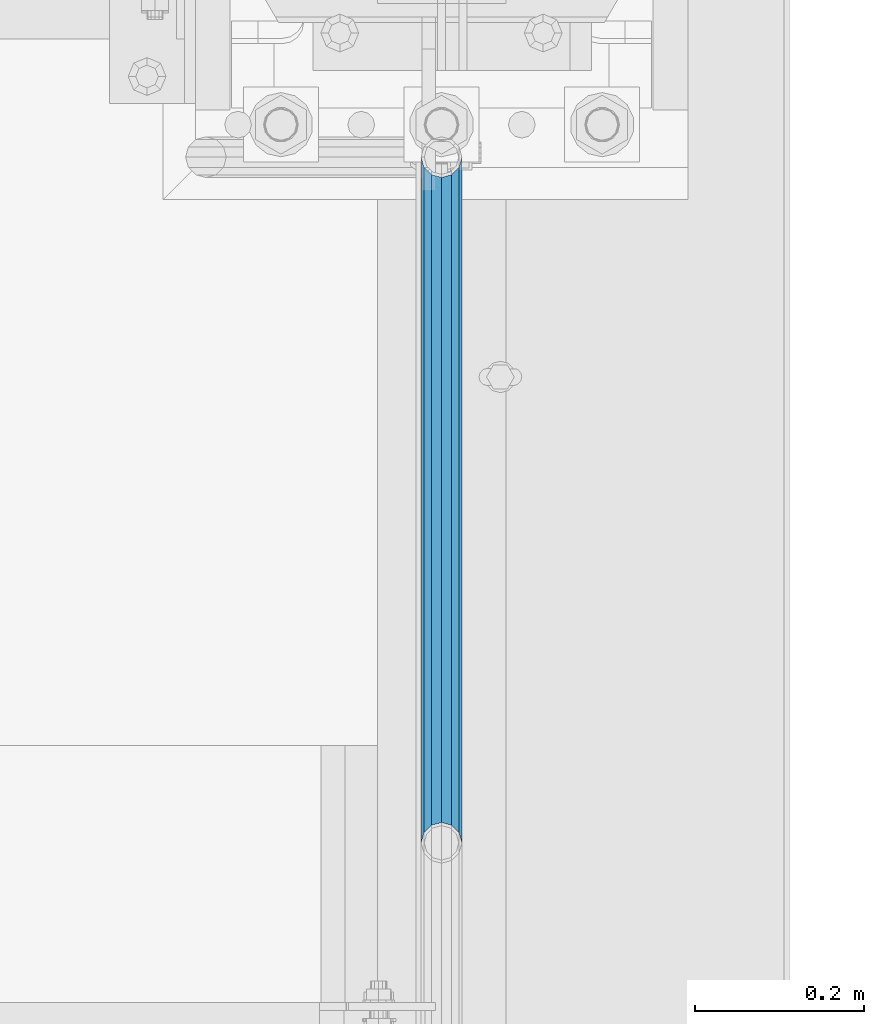
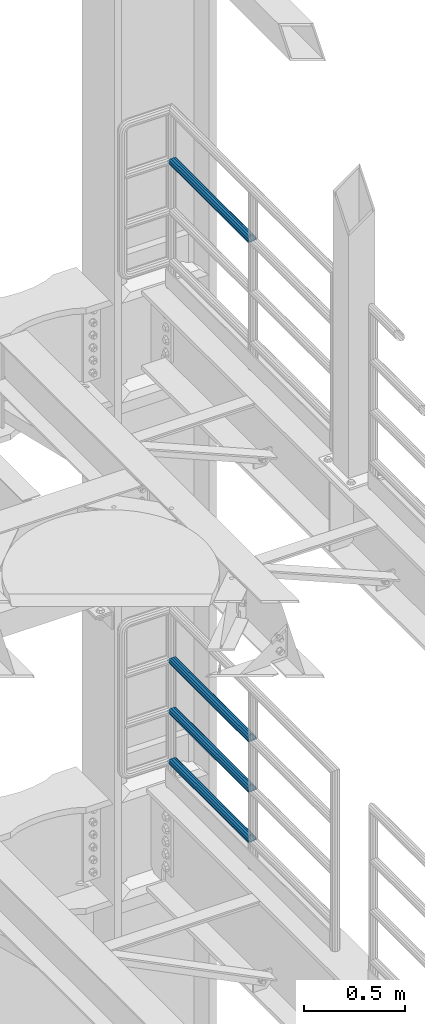
# One storey, part 1352 of 1876: 4 beams, 2 elements without a shape of their own.
"""IFC2X3 building model written with IfcOpenShell, lengths in millimetres."""

from ifc_helpers import new_model, si_unit, frame, origin_with_axes, place, context, subcontext, project, spatial, faceted_brep, material, type_object, element, aggregate, save


model = new_model("IFC2X3")

# Units and contexts
model_context = context("Model", 3, precision=1e-05, world=origin_with_axes())
body_context = subcontext(model_context, "Body", "Model", "MODEL_VIEW")
ifc_project = project(units=[si_unit("LENGTHUNIT", "METRE", prefix="MILLI"), si_unit("AREAUNIT", "SQUARE_METRE"), si_unit("VOLUMEUNIT", "CUBIC_METRE"), si_unit("MASSUNIT", "GRAM", prefix="KILO"), si_unit("TIMEUNIT", "SECOND"), si_unit("PLANEANGLEUNIT", "RADIAN"), si_unit("SOLIDANGLEUNIT", "STERADIAN"), si_unit("THERMODYNAMICTEMPERATUREUNIT", "DEGREE_CELSIUS"), si_unit("LUMINOUSINTENSITYUNIT", "LUMEN")], contexts=[model_context])

# Site, building, storey
site_placement = place(None, origin_with_axes())
site = spatial("IfcSite", under=ifc_project, at=site_placement, CompositionType="ELEMENT")
building_placement = place(site_placement, origin_with_axes())
building = spatial("IfcBuilding", under=site, at=building_placement, Name="Undefined", CompositionType="ELEMENT")
storey_placement = place(building_placement, origin_with_axes())
storey = spatial("IfcBuildingStorey", under=building, at=storey_placement, Name="Undefined", CompositionType="ELEMENT", Elevation=0.0)

# Assembly, beam
assembly_1_placement = place(storey_placement, origin_with_axes())
assembly_1 = element("IfcElementAssembly", 1, at=assembly_1_placement, inside=storey, Name="RAIL", AssemblyPlace="NOTDEFINED", PredefinedType="RIGID_FRAME")
ifc_material = material()
beam_type = type_object("IfcBeamType", Name="PIPE1-1/2SCH40", PredefinedType="NOTDEFINED")
beam_1_placement = place(assembly_1_placement, frame((7620.0, 12686.3094, 8924.925), z_axis=(0.0, 0.0, -1.0), x_axis=(0.0, 1.0, 0.0)))
beam_1 = element("IfcBeam", 2, at=beam_1_placement, type_object=beam_type, material=ifc_material, Name="RAIL", ObjectType="PIPE1-1/2SCH40", context=body_context, shape_type="Brep", body=[
    faceted_brep([(0.0, 24.1299999999992, 0.0), (12.0650000000064, 20.8971929933177, -12.0649999999987), (12.0650000000064, 20.8971929933177, 12.0649999999987), (12.0650000000064, -20.8971929933177, 12.0649999999987), (12.0650000000064, -20.8971929933177, -12.0649999999987), (0.0, -24.1299999999992, 0.0), (20.8971929933249, -12.0650000000005, 20.8971929933177), (20.8971929933249, -12.0650000000005, 15.8661214311796), (15.2545715621445, -17.7076214311801, 10.2235000000001), (12.5151929933249, -20.4470000000001, 0.0), (15.2545715621445, -17.7076214311801, -10.2235000000001), (20.8971929933249, -12.0650000000005, -15.8661214311796), (20.8971929933249, -12.0650000000005, -20.8971929933177), (24.1300000000063, 0.0, -20.4470000000001), (24.1300000000063, 0.0, -24.130000000001), (21.3906214311868, -10.2235000000001, -17.7076214311819), (21.3906214311868, 10.2235000000001, -17.7076214311819), (20.8971929933249, 12.0650000000005, -15.8661214311796), (20.8971929933249, 12.0650000000005, -20.8971929933177), (15.2545715621445, 17.7076214311801, -10.2235000000001), (12.5151929933249, 20.4470000000001, 0.0), (15.2545715621445, 17.7076214311801, 10.2235000000001), (20.8971929933249, 12.0650000000005, 15.8661214311796), (20.8971929933249, 12.0650000000005, 20.8971929933177), (21.3906214311868, 10.2235000000001, 17.7076214311819), (24.1300000000064, 0.0, 20.4470000000001), (24.1300000000064, 0.0, 24.130000000001), (21.3906214311868, -10.2235000000001, 17.7076214311819), (813.396900000002, 24.1300000000001, 0.0), (801.331900000001, 20.8971929933186, -12.0649999999987), (792.499707006684, 12.0649999999996, -20.8971929933177), (813.396900000002, -24.1300000000319, 0.0), (801.331900000001, -20.8971929933186, -12.0649999999987), (801.331900000001, -20.8971929933186, 12.0649999999987), (792.499707006684, -12.0649999999996, 20.8971929933177), (792.499707006684, -12.0649999999996, -20.8971929933177), (789.266900000001, 0.0, -24.130000000001), (792.00627856883, 10.2235000000001, -17.7076214311819), (789.266900000001, 0.0, -20.4470000000001), (792.499707006684, 12.0649999999678, -15.8661214312124), (792.499707006684, -12.0650000000314, -15.8661214311469), (792.006278568813, -10.2235000000001, -17.7076214311819), (798.142328437831, -17.7076214311801, -10.2235000000001), (800.881707006651, -20.4470000000001, 0.0), (798.142328437831, -17.7076214311801, 10.2235000000001), (792.499707006684, -12.0650000000314, 15.8661214311469), (792.006278568813, -10.2235000000001, 17.7076214311819), (789.266900000001, -9.09494701772928e-13, 20.4470000000001), (789.266900000001, -9.09494701772928e-13, 24.130000000001), (792.499707006684, 12.0649999999996, 20.8971929933177), (801.331900000001, 20.8971929933186, 12.0649999999987), (792.499707006684, 12.0649999999678, 15.8661214312124), (798.142328437896, 17.7076214311801, 10.2235000000001), (800.881707006714, 20.4470000000001, 0.0), (798.142328437896, 17.7076214311801, -10.2235000000001), (792.00627856883, 10.2235000000001, 17.7076214311819)], [[[0, 1, 2]], [[3, 4, 5]], [[6, 7, 8, 9, 10, 11, 12, 4, 3]], [[13, 14, 12, 11, 15]], [[16, 17, 18, 14, 13]], [[2, 1, 18, 17, 19, 20, 21, 22, 23]], [[23, 22, 24, 25, 26]], [[26, 25, 27, 7, 6]], [[1, 0, 28, 29]], [[18, 1, 29, 30]], [[31, 32, 33]], [[6, 3, 33, 34]], [[3, 5, 31, 33]], [[5, 4, 32, 31]], [[4, 12, 35, 32]], [[12, 14, 36, 35]], [[14, 18, 30, 36]], [[37, 38, 36, 30, 39]], [[40, 35, 36, 38, 41]], [[33, 32, 35, 40, 42, 43, 44, 45, 34]], [[34, 45, 46, 47, 48]], [[26, 6, 34, 48]], [[2, 23, 49, 50]], [[23, 26, 48, 49]], [[0, 2, 50, 28]], [[28, 50, 29]], [[49, 51, 52, 53, 54, 39, 30, 29, 50]], [[48, 47, 55, 51, 49]], [[25, 24, 55, 47]], [[55, 24, 22, 21, 52, 51]], [[21, 20, 53, 52]], [[20, 19, 54, 53]], [[19, 17, 16, 37, 39, 54]], [[16, 13, 38, 37]], [[13, 15, 41, 38]], [[41, 15, 11, 10, 42, 40]], [[10, 9, 43, 42]], [[9, 8, 44, 43]], [[8, 7, 27, 46, 45, 44]], [[27, 25, 47, 46]]]),
])
aggregate(assembly_1, [beam_1])

# Assembly, beams
assembly_2_placement = place(storey_placement, origin_with_axes())
assembly_2 = element("IfcElementAssembly", 3, at=assembly_2_placement, inside=storey, Name="RAIL", AssemblyPlace="NOTDEFINED", PredefinedType="RIGID_FRAME")
beam_2_placement = place(assembly_2_placement, frame((7620.00000000002, 13499.7063, 5292.725), z_axis=(0.0, 0.0, 1.0), x_axis=(0.0, -1.0, 0.0)))
beam_2 = element("IfcBeam", 4, at=beam_2_placement, type_object=beam_type, material=ifc_material, Name="RAIL", ObjectType="PIPE1-1/2SCH40", context=body_context, shape_type="Brep", body=[
    faceted_brep([(792.499707006684, -12.0649999999996, 20.8971929933177), (792.499707006684, -12.0650000000314, 15.8661214311469), (792.006278568813, -10.2235000000001, 17.7076214311819), (789.266900000001, -9.09494701772928e-13, 20.4470000000001), (789.266900000001, -9.09494701772928e-13, 24.130000000001), (792.00627856883, 10.2235000000001, 17.7076214311819), (792.499707006684, 12.0649999999678, 15.8661214312124), (792.499707006684, 12.0649999999996, 20.8971929933177), (813.396900000002, 24.1300000000001, 0.0), (801.331900000001, 20.8971929933186, 12.0649999999987), (801.331900000001, 20.8971929933186, -12.0649999999987), (798.142328437896, 17.7076214311801, 10.2235000000001), (800.881707006714, 20.4470000000001, 0.0), (798.142328437896, 17.7076214311801, -10.2235000000001), (792.499707006684, 12.0649999999678, -15.8661214312124), (792.499707006684, 12.0649999999996, -20.8971929933177), (792.00627856883, 10.2235000000001, -17.7076214311819), (789.266900000001, 0.0, -20.4470000000001), (789.266900000001, 0.0, -24.130000000001), (792.499707006684, -12.0650000000314, -15.8661214311469), (792.499707006684, -12.0649999999996, -20.8971929933177), (792.006278568813, -10.2235000000001, -17.7076214311819), (813.396900000002, -24.1300000000319, 0.0), (801.331900000001, -20.8971929933186, -12.0649999999987), (801.331900000001, -20.8971929933186, 12.0649999999987), (798.142328437831, -17.7076214311801, -10.2235000000001), (800.881707006651, -20.4470000000001, 0.0), (798.142328437831, -17.7076214311801, 10.2235000000001), (12.0650000000064, -20.8971929933177, -12.0649999999987), (20.8971929933249, -12.0650000000005, -20.8971929933177), (0.0, 24.1299999999992, 0.0), (12.0650000000064, 20.8971929933177, -12.0649999999987), (12.0650000000064, 20.8971929933177, 12.0649999999987), (20.8971929933249, 12.0650000000005, 20.8971929933177), (24.1300000000064, 0.0, 24.130000000001), (20.8971929933249, 12.0650000000005, -20.8971929933177), (24.1300000000063, 0.0, -24.130000000001), (24.1300000000063, 0.0, -20.4470000000001), (20.8971929933249, -12.0650000000005, -15.8661214311796), (21.3906214311868, -10.2235000000001, -17.7076214311819), (21.3906214311868, 10.2235000000001, -17.7076214311819), (20.8971929933249, 12.0650000000005, -15.8661214311796), (15.2545715621445, 17.7076214311801, -10.2235000000001), (12.5151929933249, 20.4470000000001, 0.0), (15.2545715621445, 17.7076214311801, 10.2235000000001), (20.8971929933249, 12.0650000000005, 15.8661214311796), (21.3906214311868, 10.2235000000001, 17.7076214311819), (24.1300000000064, 0.0, 20.4470000000001), (21.3906214311868, -10.2235000000001, 17.7076214311819), (20.8971929933249, -12.0650000000005, 15.8661214311796), (20.8971929933249, -12.0650000000005, 20.8971929933177), (12.0650000000064, -20.8971929933177, 12.0649999999987), (0.0, -24.1299999999992, 0.0), (15.2545715621445, -17.7076214311801, 10.2235000000001), (12.5151929933249, -20.4470000000001, 0.0), (15.2545715621445, -17.7076214311801, -10.2235000000001)], [[[0, 1, 2, 3, 4]], [[4, 3, 5, 6, 7]], [[8, 9, 10]], [[7, 6, 11, 12, 13, 14, 15, 10, 9]], [[16, 17, 18, 15, 14]], [[19, 20, 18, 17, 21]], [[22, 23, 24]], [[24, 23, 20, 19, 25, 26, 27, 1, 0]], [[28, 29, 20, 23]], [[30, 31, 32]], [[33, 34, 4, 7]], [[32, 33, 7, 9]], [[30, 32, 9, 8]], [[31, 30, 8, 10]], [[35, 31, 10, 15]], [[36, 35, 15, 18]], [[29, 36, 18, 20]], [[37, 36, 29, 38, 39]], [[40, 41, 35, 36, 37]], [[32, 31, 35, 41, 42, 43, 44, 45, 33]], [[33, 45, 46, 47, 34]], [[34, 47, 48, 49, 50]], [[34, 50, 0, 4]], [[50, 51, 24, 0]], [[51, 52, 22, 24]], [[52, 28, 23, 22]], [[51, 28, 52]], [[50, 49, 53, 54, 55, 38, 29, 28, 51]], [[55, 54, 26, 25]], [[21, 39, 38, 55, 25, 19]], [[37, 39, 21, 17]], [[40, 37, 17, 16]], [[42, 41, 40, 16, 14, 13]], [[43, 42, 13, 12]], [[44, 43, 12, 11]], [[5, 46, 45, 44, 11, 6]], [[47, 46, 5, 3]], [[48, 47, 3, 2]], [[53, 49, 48, 2, 1, 27]], [[54, 53, 27, 26]]]),
])
beam_3_placement = place(assembly_2_placement, frame((7620.0, 12686.3094, 5597.525), z_axis=(0.0, 0.0, -1.0), x_axis=(0.0, 1.0, 0.0)))
beam_3 = element("IfcBeam", 5, at=beam_3_placement, type_object=beam_type, material=ifc_material, Name="RAIL", ObjectType="PIPE1-1/2SCH40", context=body_context, shape_type="Brep", body=[
    faceted_brep([(0.0, 24.1299999999992, 0.0), (12.0650000000064, 20.8971929933177, -12.0649999999987), (12.0650000000064, 20.8971929933177, 12.0649999999987), (12.0650000000064, -20.8971929933177, 12.0649999999987), (12.0650000000064, -20.8971929933177, -12.0649999999987), (0.0, -24.1299999999992, 0.0), (20.8971929933249, -12.0650000000005, 20.8971929933177), (20.8971929933249, -12.0650000000005, 15.8661214311796), (15.2545715621445, -17.7076214311801, 10.2235000000001), (12.5151929933249, -20.4470000000001, 0.0), (15.2545715621445, -17.7076214311801, -10.2235000000001), (20.8971929933249, -12.0650000000005, -15.8661214311796), (20.8971929933249, -12.0650000000005, -20.8971929933177), (24.1300000000063, 0.0, -20.4470000000001), (24.1300000000063, 0.0, -24.130000000001), (21.3906214311868, -10.2235000000001, -17.7076214311819), (21.3906214311868, 10.2235000000001, -17.7076214311819), (20.8971929933249, 12.0650000000005, -15.8661214311796), (20.8971929933249, 12.0650000000005, -20.8971929933177), (15.2545715621445, 17.7076214311801, -10.2235000000001), (12.5151929933249, 20.4470000000001, 0.0), (15.2545715621445, 17.7076214311801, 10.2235000000001), (20.8971929933249, 12.0650000000005, 15.8661214311796), (20.8971929933249, 12.0650000000005, 20.8971929933177), (21.3906214311868, 10.2235000000001, 17.7076214311819), (24.1300000000064, 0.0, 20.4470000000001), (24.1300000000064, 0.0, 24.130000000001), (21.3906214311868, -10.2235000000001, 17.7076214311819), (813.396900000002, 24.1300000000001, 0.0), (801.331900000001, 20.8971929933186, -12.0649999999987), (792.499707006684, 12.0649999999996, -20.8971929933177), (813.396900000002, -24.1300000000319, 0.0), (801.331900000001, -20.8971929933186, -12.0649999999987), (801.331900000001, -20.8971929933186, 12.0649999999987), (792.499707006684, -12.0649999999996, 20.8971929933177), (792.499707006684, -12.0649999999996, -20.8971929933177), (789.266900000001, 0.0, -24.130000000001), (792.00627856883, 10.2235000000001, -17.7076214311819), (789.266900000001, 0.0, -20.4470000000001), (792.499707006684, 12.0649999999678, -15.8661214312124), (792.499707006684, -12.0650000000314, -15.8661214311469), (792.006278568813, -10.2235000000001, -17.7076214311819), (798.142328437831, -17.7076214311801, -10.2235000000001), (800.881707006651, -20.4470000000001, 0.0), (798.142328437831, -17.7076214311801, 10.2235000000001), (792.499707006684, -12.0650000000314, 15.8661214311469), (792.006278568813, -10.2235000000001, 17.7076214311819), (789.266900000001, -9.09494701772928e-13, 20.4470000000001), (789.266900000001, -9.09494701772928e-13, 24.130000000001), (792.499707006684, 12.0649999999996, 20.8971929933177), (801.331900000001, 20.8971929933186, 12.0649999999987), (792.499707006684, 12.0649999999678, 15.8661214312124), (798.142328437896, 17.7076214311801, 10.2235000000001), (800.881707006714, 20.4470000000001, 0.0), (798.142328437896, 17.7076214311801, -10.2235000000001), (792.00627856883, 10.2235000000001, 17.7076214311819)], [[[0, 1, 2]], [[3, 4, 5]], [[6, 7, 8, 9, 10, 11, 12, 4, 3]], [[13, 14, 12, 11, 15]], [[16, 17, 18, 14, 13]], [[2, 1, 18, 17, 19, 20, 21, 22, 23]], [[23, 22, 24, 25, 26]], [[26, 25, 27, 7, 6]], [[1, 0, 28, 29]], [[18, 1, 29, 30]], [[31, 32, 33]], [[6, 3, 33, 34]], [[3, 5, 31, 33]], [[5, 4, 32, 31]], [[4, 12, 35, 32]], [[12, 14, 36, 35]], [[14, 18, 30, 36]], [[37, 38, 36, 30, 39]], [[40, 35, 36, 38, 41]], [[33, 32, 35, 40, 42, 43, 44, 45, 34]], [[34, 45, 46, 47, 48]], [[26, 6, 34, 48]], [[2, 23, 49, 50]], [[23, 26, 48, 49]], [[0, 2, 50, 28]], [[28, 50, 29]], [[49, 51, 52, 53, 54, 39, 30, 29, 50]], [[48, 47, 55, 51, 49]], [[25, 24, 55, 47]], [[55, 24, 22, 21, 52, 51]], [[21, 20, 53, 52]], [[20, 19, 54, 53]], [[19, 17, 16, 37, 39, 54]], [[16, 13, 38, 37]], [[13, 15, 41, 38]], [[41, 15, 11, 10, 42, 40]], [[10, 9, 43, 42]], [[9, 8, 44, 43]], [[8, 7, 27, 46, 45, 44]], [[27, 25, 47, 46]]]),
])
beam_4_placement = place(assembly_2_placement, frame((7620.0, 12686.3094, 5902.325), z_axis=(0.0, 0.0, -1.0), x_axis=(0.0, 1.0, 0.0)))
beam_4 = element("IfcBeam", 6, at=beam_4_placement, type_object=beam_type, material=ifc_material, Name="RAIL", ObjectType="PIPE1-1/2SCH40", context=body_context, shape_type="Brep", body=[
    faceted_brep([(0.0, 24.1299999999992, 0.0), (12.0650000000064, 20.8971929933177, -12.0649999999987), (12.0650000000064, 20.8971929933177, 12.0649999999987), (12.0650000000064, -20.8971929933177, 12.0649999999987), (12.0650000000064, -20.8971929933177, -12.0649999999987), (0.0, -24.1299999999992, 0.0), (20.8971929933249, -12.0650000000005, 20.8971929933177), (20.8971929933249, -12.0650000000005, 15.8661214311796), (15.2545715621445, -17.7076214311801, 10.2235000000001), (12.5151929933249, -20.4470000000001, 0.0), (15.2545715621445, -17.7076214311801, -10.2235000000001), (20.8971929933249, -12.0650000000005, -15.8661214311796), (20.8971929933249, -12.0650000000005, -20.8971929933177), (24.1300000000063, 0.0, -20.4470000000001), (24.1300000000063, 0.0, -24.130000000001), (21.3906214311868, -10.2235000000001, -17.7076214311819), (21.3906214311868, 10.2235000000001, -17.7076214311819), (20.8971929933249, 12.0650000000005, -15.8661214311796), (20.8971929933249, 12.0650000000005, -20.8971929933177), (15.2545715621445, 17.7076214311801, -10.2235000000001), (12.5151929933249, 20.4470000000001, 0.0), (15.2545715621445, 17.7076214311801, 10.2235000000001), (20.8971929933249, 12.0650000000005, 15.8661214311796), (20.8971929933249, 12.0650000000005, 20.8971929933177), (21.3906214311868, 10.2235000000001, 17.7076214311819), (24.1300000000064, 0.0, 20.4470000000001), (24.1300000000064, 0.0, 24.130000000001), (21.3906214311868, -10.2235000000001, 17.7076214311819), (813.396900000002, 24.1300000000001, 0.0), (801.331900000001, 20.8971929933186, -12.0649999999987), (792.499707006684, 12.0649999999996, -20.8971929933177), (813.396900000002, -24.1300000000319, 0.0), (801.331900000001, -20.8971929933186, -12.0649999999987), (801.331900000001, -20.8971929933186, 12.0649999999987), (792.499707006684, -12.0649999999996, 20.8971929933177), (792.499707006684, -12.0649999999996, -20.8971929933177), (789.266900000001, 0.0, -24.130000000001), (792.00627856883, 10.2235000000001, -17.7076214311819), (789.266900000001, 0.0, -20.4470000000001), (792.499707006684, 12.0649999999678, -15.8661214312124), (792.499707006684, -12.0650000000314, -15.8661214311469), (792.006278568813, -10.2235000000001, -17.7076214311819), (798.142328437831, -17.7076214311801, -10.2235000000001), (800.881707006651, -20.4470000000001, 0.0), (798.142328437831, -17.7076214311801, 10.2235000000001), (792.499707006684, -12.0650000000314, 15.8661214311469), (792.006278568813, -10.2235000000001, 17.7076214311819), (789.266900000001, -9.09494701772928e-13, 20.4470000000001), (789.266900000001, -9.09494701772928e-13, 24.130000000001), (792.499707006684, 12.0649999999996, 20.8971929933177), (801.331900000001, 20.8971929933186, 12.0649999999987), (792.499707006684, 12.0649999999678, 15.8661214312124), (798.142328437896, 17.7076214311801, 10.2235000000001), (800.881707006714, 20.4470000000001, 0.0), (798.142328437896, 17.7076214311801, -10.2235000000001), (792.00627856883, 10.2235000000001, 17.7076214311819)], [[[0, 1, 2]], [[3, 4, 5]], [[6, 7, 8, 9, 10, 11, 12, 4, 3]], [[13, 14, 12, 11, 15]], [[16, 17, 18, 14, 13]], [[2, 1, 18, 17, 19, 20, 21, 22, 23]], [[23, 22, 24, 25, 26]], [[26, 25, 27, 7, 6]], [[1, 0, 28, 29]], [[18, 1, 29, 30]], [[31, 32, 33]], [[6, 3, 33, 34]], [[3, 5, 31, 33]], [[5, 4, 32, 31]], [[4, 12, 35, 32]], [[12, 14, 36, 35]], [[14, 18, 30, 36]], [[37, 38, 36, 30, 39]], [[40, 35, 36, 38, 41]], [[33, 32, 35, 40, 42, 43, 44, 45, 34]], [[34, 45, 46, 47, 48]], [[26, 6, 34, 48]], [[2, 23, 49, 50]], [[23, 26, 48, 49]], [[0, 2, 50, 28]], [[28, 50, 29]], [[49, 51, 52, 53, 54, 39, 30, 29, 50]], [[48, 47, 55, 51, 49]], [[25, 24, 55, 47]], [[55, 24, 22, 21, 52, 51]], [[21, 20, 53, 52]], [[20, 19, 54, 53]], [[19, 17, 16, 37, 39, 54]], [[16, 13, 38, 37]], [[13, 15, 41, 38]], [[41, 15, 11, 10, 42, 40]], [[10, 9, 43, 42]], [[9, 8, 44, 43]], [[8, 7, 27, 46, 45, 44]], [[27, 25, 47, 46]]]),
])
aggregate(assembly_2, [beam_2, beam_3, beam_4])

save(model, "model.ifc")
